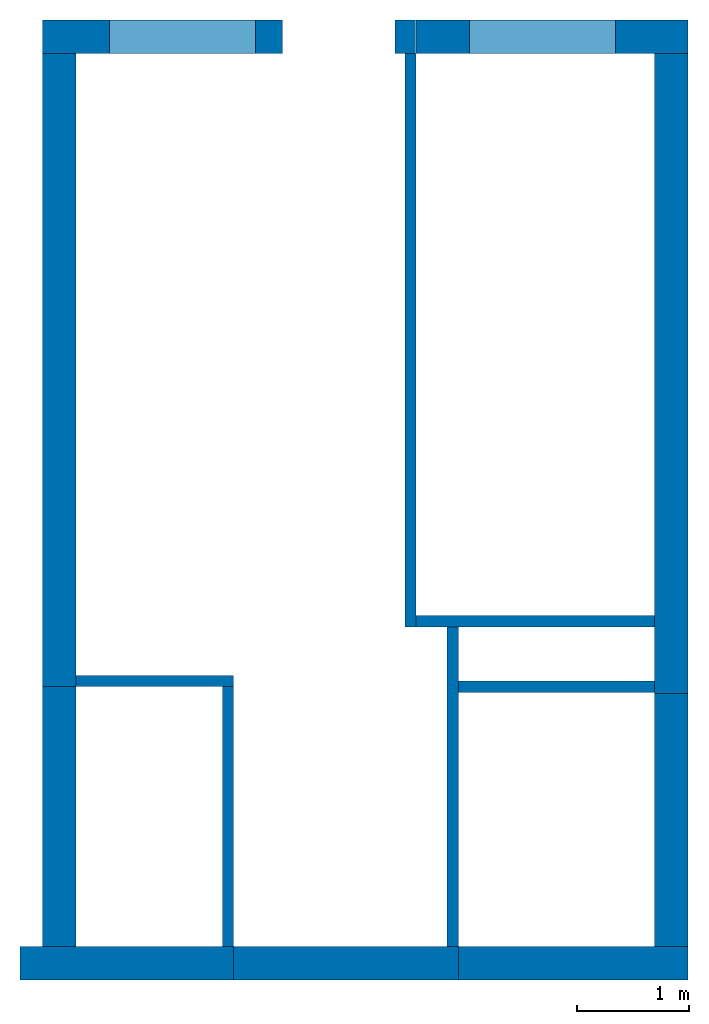
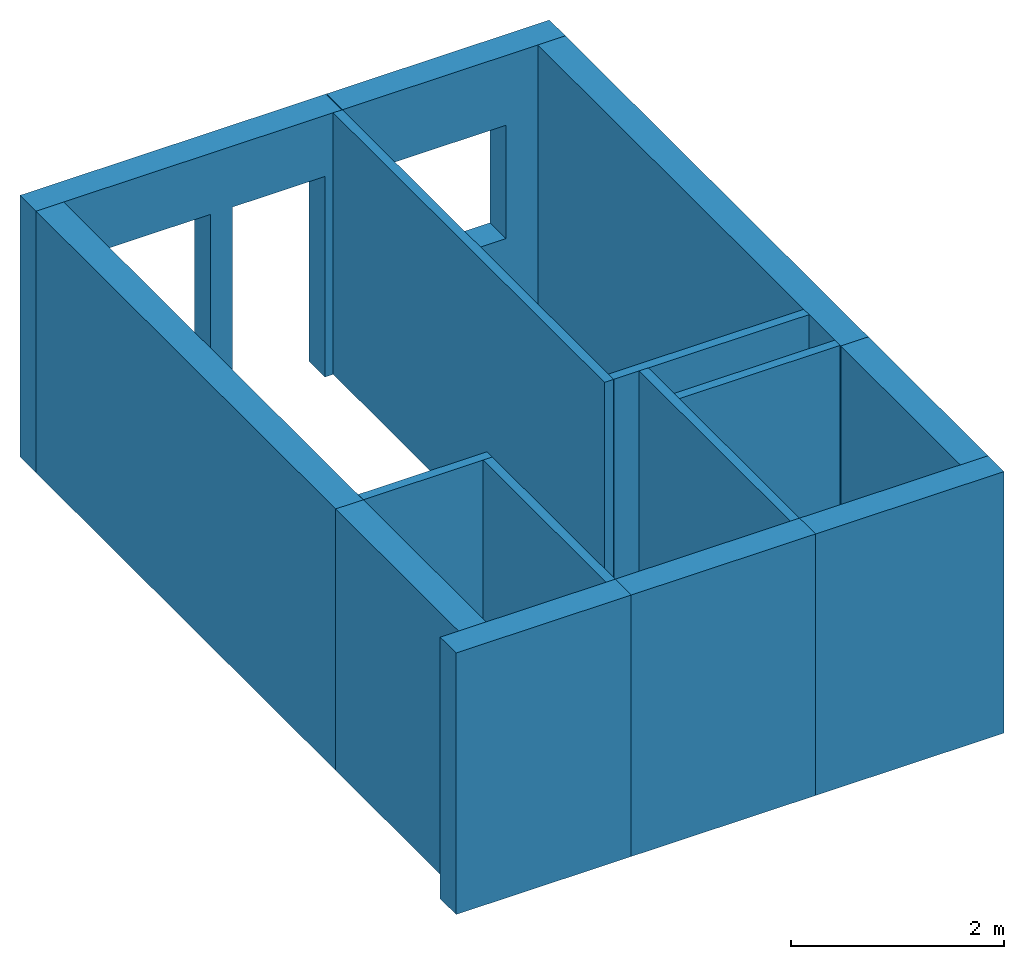
# One storey: 15 walls, 3 openings.
"""IFC4 building model written with IfcOpenShell, lengths in millimetres."""

import ifcopenshell
import ifcopenshell.guid

model = None  # the IFC model being written
_history = None  # IfcOwnerHistory: only IFC2X3 demands one
_inside = {}  # id of a spatial element -> (the spatial element, [elements in it])
_under = {}  # id of a project, library or spatial element -> (it, [spatial elements below it])
_declared = {}  # id of a project -> (the project, [libraries it declares])
_typed = {}  # id of a type object -> (the type object, [elements of that type])
_made_of = {}  # id of a material, layer set ... -> (it, [elements and type objects made of it])


def new_model(schema):
    """Start an empty IFC model of exactly this schema.

    Asked for "IFC4X3", IfcOpenShell would pick the latest addendum, in which some entities
    have other attributes; the version numbers below select the first issue.
    IFC2X3 requires an IfcOwnerHistory on every rooted entity: one is made here for all.
    """
    global model, _history
    if schema == "IFC4X3":
        model = ifcopenshell.file(schema_version=(4, 3, 0, 0))
    else:
        model = ifcopenshell.file(schema=schema)
    _inside.clear()
    _under.clear()
    _declared.clear()
    _typed.clear()
    _made_of.clear()
    _history = None
    if model.schema == "IFC2X3":
        org = make("IfcOrganization", Name="unknown")
        user = make(
            "IfcPersonAndOrganization",
            ThePerson=make("IfcPerson", FamilyName="unknown"),
            TheOrganization=org,
        )
        app = make(
            "IfcApplication",
            ApplicationDeveloper=org,
            Version="unknown",
            ApplicationFullName="unknown",
            ApplicationIdentifier="unknown",
        )
        _history = make(
            "IfcOwnerHistory",
            OwningUser=user,
            OwningApplication=app,
            ChangeAction="ADDED",
            CreationDate=0,
        )
    return model


def make(cls, **values):
    """One entity of the class cls with the attributes given. An attribute that is None is left unset."""
    return model.create_entity(
        cls, **{name: value for name, value in values.items() if value is not None}
    )


def entity(cls, *values):
    """Any entity or typed value of the class cls, its attributes in the order of the schema. None: left unset."""
    e = model.create_entity(cls)
    for i, value in enumerate(values):
        if value is not None:
            e[i] = value
    return e


def rooted(cls, **values):
    """An entity with a GlobalId (a new one), such as an element, a storey or a relation."""
    return make(cls, GlobalId=ifcopenshell.guid.new(), OwnerHistory=_history, **values)


def si_unit(unit_type, name, prefix=None):
    """IfcSIUnit, for example si_unit("LENGTHUNIT", "METRE", prefix="MILLI")."""
    return make("IfcSIUnit", UnitType=unit_type, Prefix=prefix, Name=name)


def converted_unit(unit_type, name, factor, base, dimensions=None, offset=None):
    """IfcConversionBasedUnit, such as the inch: factor (a typed value) times the base unit."""
    return make(
        "IfcConversionBasedUnit"
        if offset is None
        else "IfcConversionBasedUnitWithOffset",
        ConversionOffset=offset,
        Dimensions=None
        if dimensions is None
        else entity("IfcDimensionalExponents", *dimensions),
        UnitType=unit_type,
        Name=name,
        ConversionFactor=make(
            "IfcMeasureWithUnit", ValueComponent=factor, UnitComponent=base
        ),
    )


def assignment(units):
    """IfcUnitAssignment: the units of a project."""
    return None if units is None else make("IfcUnitAssignment", Units=units)


def point(xyz):
    """IfcCartesianPoint."""
    return None if xyz is None else make("IfcCartesianPoint", Coordinates=xyz)


def direction(xyz):
    """IfcDirection."""
    return None if xyz is None else make("IfcDirection", DirectionRatios=xyz)


def frame(location, z_axis=None, x_axis=None):
    """IfcAxis2Placement3D, a coordinate frame: its origin and axes. An axis left out is left unset."""
    return make(
        "IfcAxis2Placement3D",
        Location=point(location),
        Axis=direction(z_axis),
        RefDirection=direction(x_axis),
    )


def frame_2d(location, x_axis=None):
    """IfcAxis2Placement2D, a coordinate frame in the plane: its origin and x axis."""
    return make(
        "IfcAxis2Placement2D", Location=point(location), RefDirection=direction(x_axis)
    )


def origin_with_axes():
    """The frame at (0, 0, 0) with the z axis (0, 0, 1) and the x axis (1, 0, 0) written out."""
    return frame((0.0, 0.0, 0.0), z_axis=(0.0, 0.0, 1.0), x_axis=(1.0, 0.0, 0.0))


def origin_2d_with_axis():
    """The frame at (0, 0) in the plane with the x axis (1, 0) written out."""
    return frame_2d((0.0, 0.0), x_axis=(1.0, 0.0))


def place(relative_to, where):
    """IfcLocalPlacement: puts the frame where relative to a parent placement (None: the world)."""
    return make(
        "IfcLocalPlacement", PlacementRelTo=relative_to, RelativePlacement=where
    )


def context(
    kind, dimensions, precision=None, world=None, true_north=None, identifier=None
):
    """IfcGeometricRepresentationContext, for example the 3D "Model" context."""
    return make(
        "IfcGeometricRepresentationContext",
        ContextIdentifier=identifier,
        ContextType=kind,
        CoordinateSpaceDimension=dimensions,
        Precision=precision,
        WorldCoordinateSystem=world,
        TrueNorth=true_north,
    )


def subcontext(parent, identifier, kind, view, scale=None):
    """IfcGeometricRepresentationSubContext, for example "Body" below "Model"."""
    return make(
        "IfcGeometricRepresentationSubContext",
        ContextIdentifier=identifier,
        ContextType=kind,
        ParentContext=parent,
        TargetScale=scale,
        TargetView=view,
    )


def project(units=None, contexts=None):
    """IfcProject with its units and contexts."""
    return rooted(
        "IfcProject",
        Name="project",
        RepresentationContexts=contexts,
        UnitsInContext=assignment(units),
    )


def spatial(cls, under=None, at=None, **own):
    """A site, building, storey or space (cls), placed at a placement, below another one or the project."""
    s = rooted(cls, ObjectPlacement=at, **own)
    if under is not None:
        _under.setdefault(under.id(), (under, []))[1].append(s)
    return s


def point_list(points):
    """IfcCartesianPointList2D or 3D."""
    cls = (
        "IfcCartesianPointList2D" if len(points[0]) == 2 else "IfcCartesianPointList3D"
    )
    return make(cls, CoordList=points)


def line(*indices):
    """IfcLineIndex: a straight run through numbered points of an indexed curve."""
    return model.create_entity("IfcLineIndex", indices)


def indexed_curve(points, segments=None, self_intersect=None):
    """IfcIndexedPolyCurve: lines and arcs through numbered points (the first is 1)."""
    return make(
        "IfcIndexedPolyCurve",
        Points=point_list(points),
        Segments=segments,
        SelfIntersect=self_intersect,
    )


def outline(outer, holes=None, kind="AREA"):
    """IfcArbitraryClosedProfileDef: a profile drawn as a closed curve; with holes, ...WithVoids."""
    if holes is None:
        return make("IfcArbitraryClosedProfileDef", ProfileType=kind, OuterCurve=outer)
    return make(
        "IfcArbitraryProfileDefWithVoids",
        ProfileType=kind,
        OuterCurve=outer,
        InnerCurves=holes,
    )


def extrude(swept, where, along, depth):
    """IfcExtrudedAreaSolid: the profile swept, set in the frame where, extruded along a direction by depth."""
    return make(
        "IfcExtrudedAreaSolid",
        SweptArea=swept,
        Position=where,
        ExtrudedDirection=direction(along),
        Depth=depth,
    )


def shape(context_of_items, identifier, shape_type, items):
    """IfcShapeRepresentation: the items that make up one representation, for example the "Body"."""
    return make(
        "IfcShapeRepresentation",
        ContextOfItems=context_of_items,
        RepresentationIdentifier=identifier,
        RepresentationType=shape_type,
        Items=items,
    )


def source(mapping_origin, context_of_items, identifier, shape_type, items):
    """IfcRepresentationMap: a shape defined once, which mapped items show again and again."""
    return make(
        "IfcRepresentationMap",
        MappingOrigin=mapping_origin,
        MappedRepresentation=shape(context_of_items, identifier, shape_type, items),
    )


def transform(
    local_origin,
    x_axis=None,
    y_axis=None,
    z_axis=None,
    scale=None,
    scale2=None,
    scale3=None,
    uniform=True,
):
    """IfcCartesianTransformationOperator3D, or its non-uniform kind. x_axis, y_axis, z_axis: its Axis1, 2, 3."""
    if uniform:
        return make(
            "IfcCartesianTransformationOperator3D",
            Axis1=direction(x_axis),
            Axis2=direction(y_axis),
            LocalOrigin=point(local_origin),
            Scale=scale,
            Axis3=direction(z_axis),
        )
    return make(
        "IfcCartesianTransformationOperator3DnonUniform",
        Axis1=direction(x_axis),
        Axis2=direction(y_axis),
        LocalOrigin=point(local_origin),
        Scale=scale,
        Axis3=direction(z_axis),
        Scale2=scale2,
        Scale3=scale3,
    )


def mapped(mapping_source, mapping_target):
    """IfcMappedItem: shows the shape of a source again, moved by a transform."""
    return make(
        "IfcMappedItem", MappingSource=mapping_source, MappingTarget=mapping_target
    )


def material(Name=None, Category=None):
    """IfcMaterial."""
    return make("IfcMaterial", Name=Name, Category=Category)


def layer(
    of_material, thickness, ventilated=None, Name=None, Category=None, Priority=None
):
    """IfcMaterialLayer: one layer of a wall or slab, of a material (None: an air gap)."""
    return make(
        "IfcMaterialLayer",
        Material=of_material,
        LayerThickness=thickness,
        IsVentilated=ventilated,
        Name=Name,
        Category=Category,
        Priority=Priority,
    )


def layer_set(layers, Name=None):
    """IfcMaterialLayerSet."""
    return make("IfcMaterialLayerSet", MaterialLayers=layers, LayerSetName=Name)


def layer_usage(for_layer_set, set_direction, sense, offset, extent=None):
    """IfcMaterialLayerSetUsage: how a layer set lies in its element."""
    return make(
        "IfcMaterialLayerSetUsage",
        ForLayerSet=for_layer_set,
        LayerSetDirection=set_direction,
        DirectionSense=sense,
        OffsetFromReferenceLine=offset,
        ReferenceExtent=extent,
    )


def made_of(thing, what):
    """Note that an element or type object is made of a material, layer set ...; save() writes the relation."""
    if what is not None:
        _made_of.setdefault(what.id(), (what, []))[1].append(thing)
    return thing


def type_object(cls, material=None, **own):
    """A type object (cls), such as IfcWallType, which elements share."""
    return made_of(rooted(cls, **own), material)


def element(
    cls,
    number,
    at=None,
    inside=None,
    cuts=None,
    type_object=None,
    material=None,
    context=None,
    identifier="Body",
    shape_type=None,
    held_by="IfcProductDefinitionShape",
    body=None,
    shapes=None,
    **own,
):
    """One element of the class cls, such as IfcWall. Its Tag is "e" and its number.

    at: its placement. inside: the storey or other place that contains it. cuts: it is an
    opening in that element (IfcRelVoidsElement). A single representation is given by context,
    identifier, shape_type and body (its items); several are given by shapes. held_by: the class
    of the entity that holds the representations. save() writes the other relations.
    """
    e = rooted(cls, Tag="e%d" % number, ObjectPlacement=at, **own)
    if body is not None:
        shapes = [shape(context, identifier, shape_type, body)]
    if shapes is not None:
        e.Representation = make(held_by, Representations=shapes)
    if inside is not None:
        _inside.setdefault(inside.id(), (inside, []))[1].append(e)
    if cuts is not None:
        rooted(
            "IfcRelVoidsElement", RelatingBuildingElement=cuts, RelatedOpeningElement=e
        )
    if type_object is not None:
        _typed.setdefault(type_object.id(), (type_object, []))[1].append(e)
    return made_of(e, material)


def aggregate(whole, parts):
    """IfcRelAggregates: a whole, such as a stair, and the parts it consists of."""
    return rooted("IfcRelAggregates", RelatingObject=whole, RelatedObjects=parts)


def save(model, path):
    """Write the relations noted so far, then the file.

    IfcRelAggregates (storeys below a building ...), IfcRelContainedInSpatialStructure (elements
    in a storey), IfcRelDefinesByType, IfcRelAssociatesMaterial and IfcRelDeclares: one each for
    every whole, place, type object, material and project.
    """
    for whole, parts in _under.values():
        aggregate(whole, parts)
    for where, things in _inside.values():
        rooted(
            "IfcRelContainedInSpatialStructure",
            RelatedElements=things,
            RelatingStructure=where,
        )
    for kind, things in _typed.values():
        rooted("IfcRelDefinesByType", RelatedObjects=things, RelatingType=kind)
    for what, things in _made_of.values():
        rooted("IfcRelAssociatesMaterial", RelatedObjects=things, RelatingMaterial=what)
    for by, libraries in _declared.values():
        rooted("IfcRelDeclares", RelatingContext=by, RelatedDefinitions=libraries)
    model.write(path)


model = new_model("IFC4")

# Units and contexts
model_context = context("Model", 3, precision=1e-05, world=origin_with_axes())
plan_context = context("Plan", 2, precision=1e-05, world=origin_2d_with_axis())
body_context = subcontext(model_context, "Body", "Model", "MODEL_VIEW")
ifc_project = project(units=[si_unit("AREAUNIT", "SQUARE_METRE", prefix="MILLI"), si_unit("VOLUMEUNIT", "CUBIC_METRE", prefix="MILLI"), si_unit("LENGTHUNIT", "METRE", prefix="MILLI"), converted_unit("PLANEANGLEUNIT", "degree", entity("IfcReal", 0.0174532925199433), si_unit("PLANEANGLEUNIT", "RADIAN"), dimensions=[0, 0, 0, 0, 0, 0, 0])], contexts=[model_context, plan_context])

# Site, building, storey
site_placement = place(None, origin_with_axes())
site = spatial("IfcSite", under=ifc_project, at=site_placement)
building_placement = place(site_placement, origin_with_axes())
building = spatial("IfcBuilding", under=site, at=building_placement, Name="Building")
storey_placement = place(building_placement, origin_with_axes())
storey = spatial("IfcBuildingStorey", under=building, at=storey_placement, Name="Storey")

# Walls
ifc_material = material()
ifc_layer_1 = layer(ifc_material, 100.0)
ifc_layer_set_1 = layer_set([ifc_layer_1])
ifc_layer_usage_1 = layer_usage(ifc_layer_set_1, "AXIS2", "POSITIVE", 0.0)
wall_type_1 = type_object("IfcWallType", Name="WAL100", PredefinedType="NOTDEFINED", material=ifc_layer_set_1)
wall_1_placement = place(storey_placement, frame((2920.00007629395, 0.0, 0.0), z_axis=(0.0, 0.0, 1.0), x_axis=(-4.37113882867379e-08, -1.0, 0.0)))
element("IfcWall", 1, at=wall_1_placement, inside=storey, type_object=wall_type_1, material=ifc_layer_usage_1, Name="Wall", PredefinedType="NOTDEFINED", context=body_context, shape_type="SweptSolid", body=[
    extrude(outline(indexed_curve([(0.0, 0.0), (0.0, 100.0), (5099.99983544445, 100.0), (5099.99983544445, 0.0), (0.0, 0.0)], self_intersect=False)), origin_with_axes(), (0.0, 0.0, 1.0), 3000.0),
])
ifc_layer_usage_2 = layer_usage(ifc_layer_set_1, "AXIS2", "POSITIVE", 0.0)
wall_2_placement = place(storey_placement, frame((1395.59733867645, -5531.96096420288, 0.0), z_axis=(0.0, 0.0, 1.0), x_axis=(-1.0, 6.27832946520357e-07, 0.0)))
element("IfcWall", 2, at=wall_2_placement, inside=storey, type_object=wall_type_1, material=ifc_layer_usage_2, Name="Wall", PredefinedType="NOTDEFINED", context=body_context, shape_type="SweptSolid", body=[
    extrude(outline(indexed_curve([(0.0, 0.0), (0.0, 100.0), (1399.99984332525, 100.0), (1399.99984332525, 0.0), (0.0, 0.0)], self_intersect=False)), origin_with_axes(), (0.0, 0.0, 1.0), 3000.0),
])
ifc_layer_usage_3 = layer_usage(ifc_layer_set_1, "AXIS2", "POSITIVE", 0.0)
wall_3_placement = place(storey_placement, frame((1295.59731483459, -5631.96086883545, 0.0), z_axis=(0.0, 0.0, 1.0), x_axis=(-6.39757843146072e-07, -1.0, 0.0)))
element("IfcWall", 3, at=wall_3_placement, inside=storey, type_object=wall_type_1, material=ifc_layer_usage_3, Name="Wall", PredefinedType="NOTDEFINED", context=body_context, shape_type="SweptSolid", body=[
    extrude(outline(indexed_curve([(0.0, 0.0), (0.0, 100.0), (2309.99991875234, 100.0), (2309.99991875234, 0.0), (0.0, 0.0)], self_intersect=False)), origin_with_axes(), (0.0, 0.0, 1.0), 3000.0),
])
ifc_layer_usage_4 = layer_usage(ifc_layer_set_1, "AXIS2", "POSITIVE", 0.0)
wall_4_placement = place(storey_placement, frame((3295.59922218323, -5099.99990463257, 0.0), z_axis=(0.0, 0.0, 1.0), x_axis=(-1.35501352360734e-06, -1.0, 0.0)))
element("IfcWall", 4, at=wall_4_placement, inside=storey, type_object=wall_type_1, material=ifc_layer_usage_4, Name="Wall", PredefinedType="NOTDEFINED", context=body_context, shape_type="SweptSolid", body=[
    extrude(outline(indexed_curve([(0.0, 0.0), (0.0, 100.0), (2841.96231531143, 100.0), (2841.96231531143, 0.0), (0.0, 0.0)], self_intersect=False)), origin_with_axes(), (0.0, 0.0, 1.0), 3000.0),
])
ifc_layer_usage_5 = layer_usage(ifc_layer_set_1, "AXIS2", "POSITIVE", 0.0)
wall_5_placement = place(storey_placement, frame((3395.59841156006, -5681.96201324463, 0.0), z_axis=(0.0, 0.0, 1.0), x_axis=(1.0, -1.43051147460938e-06, 0.0)))
element("IfcWall", 5, at=wall_5_placement, inside=storey, type_object=wall_type_1, material=ifc_layer_usage_5, Name="Wall", PredefinedType="NOTDEFINED", context=body_context, shape_type="SweptSolid", body=[
    extrude(outline(indexed_curve([(0.0, 0.0), (0.0, 100.0), (1744.40525008364, 100.0), (1744.40525008364, 0.0), (0.0, 0.0)], self_intersect=False)), origin_with_axes(), (0.0, 0.0, 1.0), 3000.0),
])
ifc_layer_usage_6 = layer_usage(ifc_layer_set_1, "AXIS2", "POSITIVE", 0.0)
wall_6_placement = place(storey_placement, frame((3020.00117301941, -5099.99990463257, 0.0), z_axis=(0.0, 0.0, 1.0), x_axis=(1.0, 4.76837158203125e-07, 0.0)))
element("IfcWall", 6, at=wall_6_placement, inside=storey, type_object=wall_type_1, material=ifc_layer_usage_6, Name="Wall", PredefinedType="NOTDEFINED", context=body_context, shape_type="SweptSolid", body=[
    extrude(outline(indexed_curve([(0.0, 0.0), (0.0, 100.0), (2120.00113037389, 100.0), (2120.00113037389, 0.0), (0.0, 0.0)], self_intersect=False)), origin_with_axes(), (0.0, 0.0, 1.0), 3000.0),
])

# Wall, openings
ifc_layer_2 = layer(ifc_material, 300.0)
ifc_layer_set_2 = layer_set([ifc_layer_2])
ifc_layer_usage_7 = layer_usage(ifc_layer_set_2, "AXIS2", "POSITIVE", 0.0)
wall_type_2 = type_object("IfcWallType", Name="WAL300", PredefinedType="NOTDEFINED", material=ifc_layer_set_2)
wall_7_placement = place(storey_placement, frame((-304.254531860352, 0.0, 0.0), z_axis=(0.0, 0.0, 1.0), x_axis=(1.0, 0.0, 0.0)))
wall_7 = element("IfcWall", 7, at=wall_7_placement, inside=storey, type_object=wall_type_2, material=ifc_layer_usage_7, Name="Wall", PredefinedType="NOTDEFINED", context=body_context, shape_type="SweptSolid", body=[
    extrude(outline(indexed_curve([(0.0, 0.0), (0.0, 300.0), (3317.52252382798, 300.0), (3317.52252382798, 0.0), (0.0, 0.0)], self_intersect=False)), origin_with_axes(), (0.0, 0.0, 1.0), 3000.0),
])
shared_shape_1 = source(origin_with_axes(), body_context, "Body", "SweptSolid", [
    extrude(outline(indexed_curve([(0.0, 0.0, 0.0), (1300.0, 0.0, 0.0), (1300.0, 0.0, 2200.0), (0.0, 0.0, 2200.0)], segments=[line(1, 2), line(2, 3), line(3, 4), line(4, 1)])), frame((0.0, -100.0, 0.0), z_axis=(0.0, 0.0, 1.0), x_axis=(1.0, 0.0, 0.0)), (0.0, 1.0, 0.0), 500.000011920929),
])
opening_1_placement = place(wall_7_placement, frame((594.254523515702, 50.0000044703484, 100.000001490116), z_axis=(0.0, 0.0, 1.0), x_axis=(1.0, 0.0, 0.0)))
element("IfcOpeningElement", 8, at=opening_1_placement, cuts=wall_7, PredefinedType="OPENING", context=body_context, shape_type="MappedRepresentation", body=[
    mapped(shared_shape_1, transform((0.0, 0.0, 0.0), x_axis=(1.0, 0.0, 0.0), y_axis=(0.0, 1.0, 0.0), z_axis=(0.0, 0.0, 1.0), scale=1.0)),
])
shared_shape_2 = source(origin_with_axes(), body_context, "Body", "SweptSolid", [
    extrude(outline(indexed_curve([(0.0, 0.0, 0.0), (1000.0, 0.0, 0.0), (1000.0, 0.0, 2300.0), (0.0, 0.0, 2300.0)], segments=[line(1, 2), line(2, 3), line(3, 4), line(4, 1)])), frame((0.0, -100.0, 0.0), z_axis=(0.0, 0.0, 1.0), x_axis=(1.0, 0.0, 0.0)), (0.0, 1.0, 0.0), 500.000011920929),
])
opening_2_placement = place(wall_7_placement, frame((2134.88757610321, 0.0, 0.0), z_axis=(0.0, 0.0, 1.0), x_axis=(1.0, 0.0, 0.0)))
element("IfcOpeningElement", 9, at=opening_2_placement, cuts=wall_7, PredefinedType="OPENING", context=body_context, shape_type="MappedRepresentation", body=[
    mapped(shared_shape_2, transform((0.0, 0.0, 0.0), x_axis=(1.0, 0.0, 0.0), y_axis=(0.0, 1.0, 0.0), z_axis=(0.0, 0.0, 1.0), scale=1.0)),
])

# Wall, opening
ifc_layer_usage_8 = layer_usage(ifc_layer_set_2, "AXIS2", "POSITIVE", 0.0)
wall_8_placement = place(storey_placement, frame((3019.99998092651, 2.23517417907715e-05, 0.0), z_axis=(0.0, 0.0, 1.0), x_axis=(1.0, 4.76837158203125e-07, 0.0)))
wall_8 = element("IfcWall", 10, at=wall_8_placement, inside=storey, type_object=wall_type_2, material=ifc_layer_usage_8, Name="Wall", PredefinedType="NOTDEFINED", context=body_context, shape_type="SweptSolid", body=[
    extrude(outline(indexed_curve([(0.0, 0.0), (0.0, 300.0), (2420.00010120009, 300.0), (2420.00010120009, 0.0), (0.0, 0.0)], self_intersect=False)), origin_with_axes(), (0.0, 0.0, 1.0), 3000.0),
])
shared_shape_3 = source(origin_with_axes(), body_context, "Body", "SweptSolid", [
    extrude(outline(indexed_curve([(0.0, 0.0, 0.0), (1300.0, 0.0, 0.0), (1300.0, 0.0, 1300.0), (0.0, 0.0, 1300.0)], segments=[line(1, 2), line(2, 3), line(3, 4), line(4, 1)])), frame((0.0, -100.0, 0.0), z_axis=(0.0, 0.0, 1.0), x_axis=(1.0, 0.0, 0.0)), (0.0, 1.0, 0.0), 500.000011920929),
])
opening_3_placement = place(wall_8_placement, frame((474.081993103088, 0.000119209289550752, 900.000035762787), z_axis=(0.0, 0.0, 1.0), x_axis=(1.0, 0.0, 0.0)))
element("IfcOpeningElement", 11, at=opening_3_placement, cuts=wall_8, PredefinedType="OPENING", context=body_context, shape_type="MappedRepresentation", body=[
    mapped(shared_shape_3, transform((0.0, 0.0, 0.0), x_axis=(1.0, 0.0, 0.0), y_axis=(0.0, 1.0, 0.0), z_axis=(0.0, 0.0, 1.0), scale=1.0)),
])

# Walls
ifc_layer_usage_9 = layer_usage(ifc_layer_set_2, "AXIS2", "POSITIVE", 0.0)
wall_9_placement = place(storey_placement, frame((5139.9998664856, 0.00104308128356934, 0.0), z_axis=(0.0, 0.0, 1.0), x_axis=(4.3312576281096e-07, -1.0, 0.0)))
element("IfcWall", 12, at=wall_9_placement, inside=storey, type_object=wall_type_2, material=ifc_layer_usage_9, Name="Wall", PredefinedType="NOTDEFINED", context=body_context, shape_type="SweptSolid", body=[
    extrude(outline(indexed_curve([(0.0, 0.0), (0.0, 300.0), (5693.81899409877, 300.0), (5693.81899409877, 0.0), (0.0, 0.0)], self_intersect=False)), origin_with_axes(), (0.0, 0.0, 1.0), 3000.0),
])
ifc_layer_usage_10 = layer_usage(ifc_layer_set_2, "AXIS2", "POSITIVE", 0.0)
wall_10_placement = place(storey_placement, frame((-4.22176765277982, -5631.95991516113, 0.0), z_axis=(0.0, 0.0, 1.0), x_axis=(3.13916473260178e-07, 1.0, 0.0)))
element("IfcWall", 13, at=wall_10_placement, inside=storey, type_object=wall_type_2, material=ifc_layer_usage_10, Name="Wall", PredefinedType="NOTDEFINED", context=body_context, shape_type="SweptSolid", body=[
    extrude(outline(indexed_curve([(0.0, 0.0), (0.0, 300.0), (5639.99939722397, 300.0), (5639.99939722397, 0.0), (0.0, 0.0)], self_intersect=False)), origin_with_axes(), (0.0, 0.0, 1.0), 3000.0),
])
ifc_layer_usage_11 = layer_usage(ifc_layer_set_2, "AXIS2", "POSITIVE", 0.0)
wall_11_placement = place(storey_placement, frame((-4.40431712195277, -8241.95957183838, 0.0), z_axis=(0.0, 0.0, 1.0), x_axis=(6.71544341912522e-07, 1.0, 0.0)))
element("IfcWall", 14, at=wall_11_placement, inside=storey, type_object=wall_type_2, material=ifc_layer_usage_11, Name="Wall", PredefinedType="NOTDEFINED", context=body_context, shape_type="SweptSolid", body=[
    extrude(outline(indexed_curve([(0.0, 0.0), (0.0, 300.0), (2609.99962189245, 300.0), (2609.99962189245, 0.0), (0.0, 0.0)], self_intersect=False)), origin_with_axes(), (0.0, 0.0, 1.0), 3000.0),
])
ifc_layer_usage_12 = layer_usage(ifc_layer_set_2, "AXIS2", "POSITIVE", 0.0)
wall_12_placement = place(storey_placement, frame((1395.59578895569, -7941.96081161499, 0.0), z_axis=(0.0, 0.0, 1.0), x_axis=(-1.0, 8.66251525621919e-07, 0.0)))
element("IfcWall", 15, at=wall_12_placement, inside=storey, type_object=wall_type_2, material=ifc_layer_usage_12, Name="Wall", PredefinedType="NOTDEFINED", context=body_context, shape_type="SweptSolid", body=[
    extrude(outline(indexed_curve([(0.0, 0.0), (0.0, 300.0), (1899.99997239418, 300.0), (1899.99997239418, 0.0), (0.0, 0.0)], self_intersect=False)), origin_with_axes(), (0.0, 0.0, 1.0), 3000.0),
])
ifc_layer_usage_13 = layer_usage(ifc_layer_set_2, "AXIS2", "POSITIVE", 0.0)
wall_13_placement = place(storey_placement, frame((1395.59555053711, -8241.9605255127, 0.0), z_axis=(0.0, 0.0, 1.0), x_axis=(1.0, -8.34465026855469e-07, 0.0)))
element("IfcWall", 16, at=wall_13_placement, inside=storey, type_object=wall_type_2, material=ifc_layer_usage_13, Name="Wall", PredefinedType="NOTDEFINED", context=body_context, shape_type="SweptSolid", body=[
    extrude(outline(indexed_curve([(0.0, 0.0), (0.0, 300.0), (1999.99976158232, 300.0), (1999.99976158232, 0.0), (0.0, 0.0)], self_intersect=False)), origin_with_axes(), (0.0, 0.0, 1.0), 3000.0),
])
ifc_layer_usage_14 = layer_usage(ifc_layer_set_2, "AXIS2", "POSITIVE", 0.0)
wall_14_placement = place(storey_placement, frame((5440.00005722046, -7941.96510314941, 0.0), z_axis=(0.0, 0.0, 1.0), x_axis=(-1.0, 1.58150726292661e-06, 0.0)))
element("IfcWall", 17, at=wall_14_placement, inside=storey, type_object=wall_type_2, material=ifc_layer_usage_14, Name="Wall", PredefinedType="NOTDEFINED", context=body_context, shape_type="SweptSolid", body=[
    extrude(outline(indexed_curve([(0.0, 0.0), (0.0, 300.0), (2044.40473049444, 300.0), (2044.40473049444, 0.0), (0.0, 0.0)], self_intersect=False)), origin_with_axes(), (0.0, 0.0, 1.0), 3000.0),
])
ifc_layer_usage_15 = layer_usage(ifc_layer_set_2, "AXIS2", "POSITIVE", 0.0)
wall_15_placement = place(storey_placement, frame((5140.00368118286, -5693.81809234619, 0.0), z_axis=(0.0, 0.0, 1.0), x_axis=(-1.47422281315812e-06, -1.0, 0.0)))
element("IfcWall", 18, at=wall_15_placement, inside=storey, type_object=wall_type_2, material=ifc_layer_usage_15, Name="Wall", PredefinedType="NOTDEFINED", context=body_context, shape_type="SweptSolid", body=[
    extrude(outline(indexed_curve([(0.0, 0.0), (0.0, 300.0), (2248.14698951954, 300.0), (2248.14698951954, 0.0), (0.0, 0.0)], self_intersect=False)), origin_with_axes(), (0.0, 0.0, 1.0), 3000.0),
])

save(model, "model.ifc")
